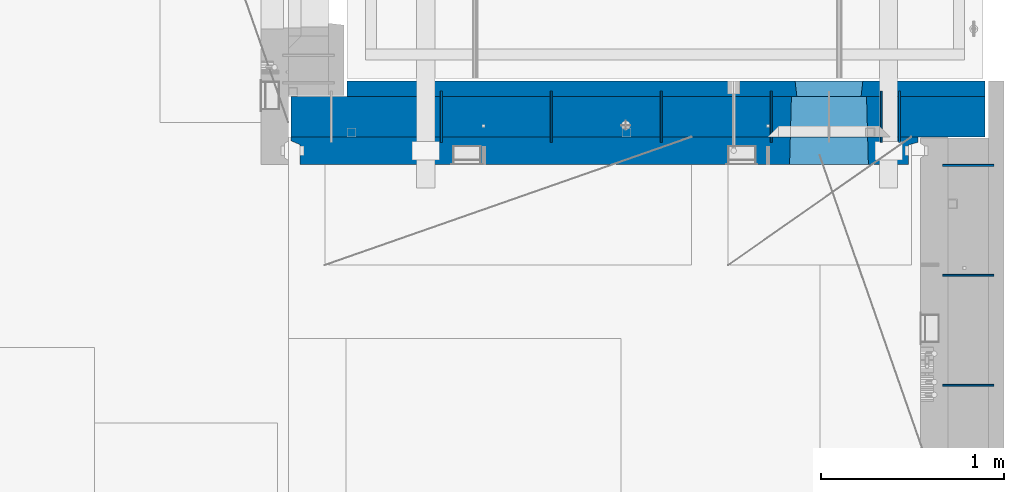
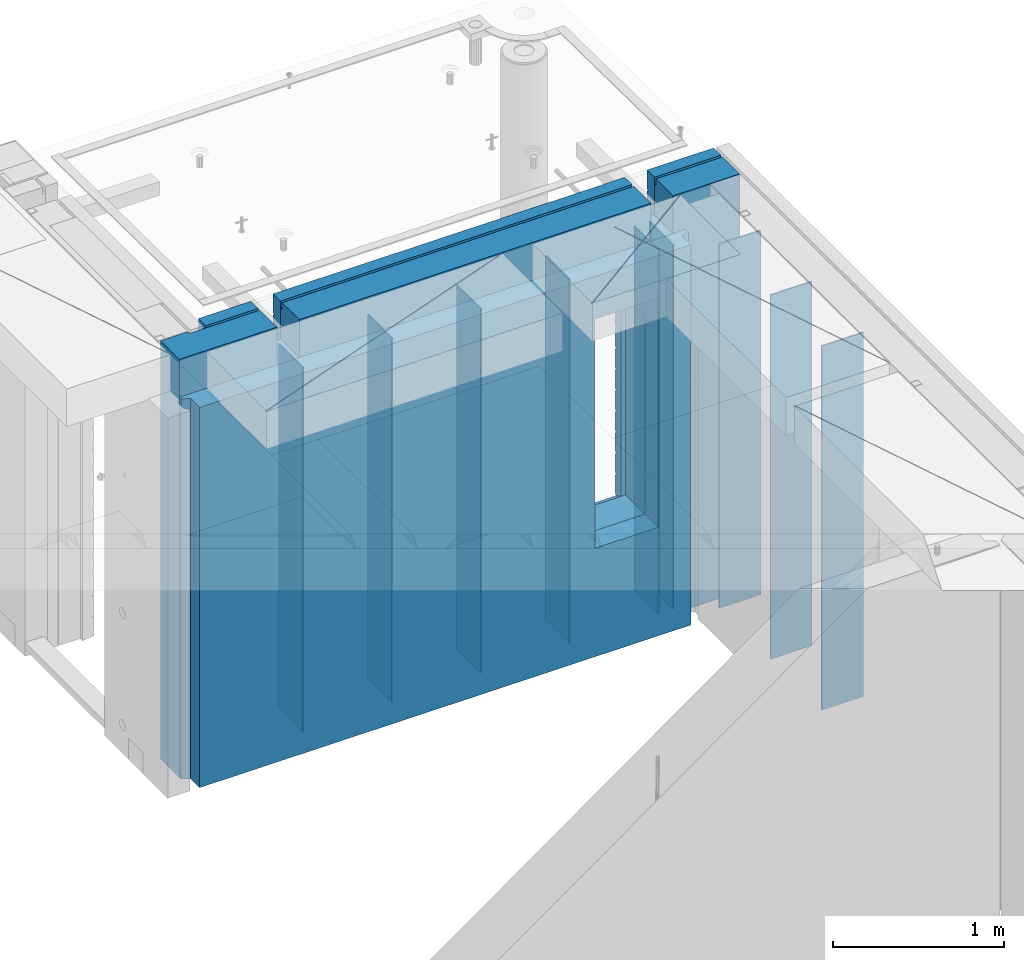
# One storey, part 234 of 341: 12 walls, 2 elements without a shape of their own.
"""IFC2X3 building model written with IfcOpenShell, lengths in millimetres."""

from ifc_helpers import new_model, si_unit, frame, origin_with_axes, place, context, subcontext, project, spatial, faceted_brep, material, type_object, element, aggregate, save


model = new_model("IFC2X3")

# Units and contexts
model_context = context("Model", 3, precision=1e-05, world=origin_with_axes())
body_context = subcontext(model_context, "Body", "Model", "MODEL_VIEW")
ifc_project = project(units=[si_unit("LENGTHUNIT", "METRE", prefix="MILLI"), si_unit("AREAUNIT", "SQUARE_METRE"), si_unit("VOLUMEUNIT", "CUBIC_METRE"), si_unit("MASSUNIT", "GRAM", prefix="KILO"), si_unit("TIMEUNIT", "SECOND"), si_unit("PLANEANGLEUNIT", "RADIAN"), si_unit("SOLIDANGLEUNIT", "STERADIAN"), si_unit("THERMODYNAMICTEMPERATUREUNIT", "DEGREE_CELSIUS"), si_unit("LUMINOUSINTENSITYUNIT", "LUMEN")], contexts=[model_context])

# Site, building, storey
site_placement = place(None, origin_with_axes())
site = spatial("IfcSite", under=ifc_project, at=site_placement, CompositionType="ELEMENT")
building_placement = place(site_placement, origin_with_axes())
building = spatial("IfcBuilding", under=site, at=building_placement, CompositionType="ELEMENT")
storey_placement = place(building_placement, origin_with_axes())
storey = spatial("IfcBuildingStorey", under=building, at=storey_placement, Name="5", CompositionType="ELEMENT", Elevation=0.0)

# Assembly, walls
assembly_1_placement = place(storey_placement, origin_with_axes())
assembly_1 = element("IfcElementAssembly", 1, at=assembly_1_placement, inside=storey, AssemblyPlace="NOTDEFINED", PredefinedType="REINFORCEMENT_UNIT")
ifc_material_1 = material(Name="Undefined")
wall_type_1 = type_object("IfcWallType", PredefinedType="NOTDEFINED")
wall_1_placement = place(assembly_1_placement, frame((32295.0, 20549.9951872276, 95115.0), z_axis=(0.0, 0.0, 1.0), x_axis=(0.0, 1.0, 0.0)))
wall_1 = element("IfcWall", 2, at=wall_1_placement, type_object=wall_type_1, material=ifc_material_1, Name="(PD)", context=body_context, shape_type="Brep", body=[
    faceted_brep([(0.0, 5.0, -1300.0), (0.0, 5.0, 1300.0), (280.0, 5.0, 1300.0), (280.0, 5.0, -1300.0), (0.0, -5.0, 1300.0), (280.0, -5.0, 1300.0), (0.0, -5.0, -1300.0), (280.0, -5.0, -1300.0)], [[[0, 1, 2, 3]], [[1, 4, 5, 2]], [[4, 6, 7, 5]], [[6, 0, 3, 7]], [[5, 7, 3, 2]], [[6, 4, 1, 0]]]),
])
wall_2_placement = place(assembly_1_placement, frame((32895.0, 20549.9951872276, 95115.0), z_axis=(0.0, 0.0, 1.0), x_axis=(0.0, 1.0, 0.0)))
wall_2 = element("IfcWall", 3, at=wall_2_placement, type_object=wall_type_1, material=ifc_material_1, Name="(PD)", context=body_context, shape_type="Brep", body=[
    faceted_brep([(0.0, 5.0, -1300.0), (0.0, 5.0, 1300.0), (280.0, 5.0, 1300.0), (280.0, 5.0, -1300.0), (0.0, -5.0, 1300.0), (280.0, -5.0, 1300.0), (0.0, -5.0, -1300.0), (280.0, -5.0, -1300.0)], [[[0, 1, 2, 3]], [[1, 4, 5, 2]], [[4, 6, 7, 5]], [[6, 0, 3, 7]], [[5, 7, 3, 2]], [[6, 4, 1, 0]]]),
])
wall_3_placement = place(assembly_1_placement, frame((33495.0, 20549.9951872276, 95115.0), z_axis=(0.0, 0.0, 1.0), x_axis=(0.0, 1.0, 0.0)))
wall_3 = element("IfcWall", 4, at=wall_3_placement, type_object=wall_type_1, material=ifc_material_1, Name="(PD)", context=body_context, shape_type="Brep", body=[
    faceted_brep([(0.0, 5.0, -1300.0), (0.0, 5.0, 1300.0), (280.0, 5.0, 1300.0), (280.0, 5.0, -1300.0), (0.0, -5.0, 1300.0), (280.0, -5.0, 1300.0), (0.0, -5.0, -1300.0), (280.0, -5.0, -1300.0)], [[[0, 1, 2, 3]], [[1, 4, 5, 2]], [[4, 6, 7, 5]], [[6, 0, 3, 7]], [[5, 7, 3, 2]], [[6, 4, 1, 0]]]),
])
wall_4_placement = place(assembly_1_placement, frame((34695.0, 20549.9951872276, 95115.0), z_axis=(0.0, 0.0, 1.0), x_axis=(0.0, 1.0, 0.0)))
wall_4 = element("IfcWall", 5, at=wall_4_placement, type_object=wall_type_1, material=ifc_material_1, Name="(PD)", context=body_context, shape_type="Brep", body=[
    faceted_brep([(0.0, 5.0, -1300.0), (0.0, 5.0, 1300.0), (280.0, 5.0, 1300.0), (280.0, 5.0, -1300.0), (0.0, -5.0, 1300.0), (280.0, -5.0, 1300.0), (0.0, -5.0, -1300.0), (280.0, -5.0, -1300.0)], [[[0, 1, 2, 3]], [[1, 4, 5, 2]], [[4, 6, 7, 5]], [[6, 0, 3, 7]], [[5, 7, 3, 2]], [[6, 4, 1, 0]]]),
])
wall_5_placement = place(assembly_1_placement, frame((34795.0, 20549.9951872276, 95115.0), z_axis=(0.0, 0.0, 1.0), x_axis=(0.0, 1.0, 0.0)))
wall_5 = element("IfcWall", 6, at=wall_5_placement, type_object=wall_type_1, material=ifc_material_1, Name="(PD)", context=body_context, shape_type="Brep", body=[
    faceted_brep([(0.0, 5.0, -1300.0), (0.0, 5.0, 1300.0), (280.0, 5.0, 1300.0), (280.0, 5.0, -1300.0), (0.0, -5.0, 1300.0), (280.0, -5.0, 1300.0), (0.0, -5.0, -1300.0), (280.0, -5.0, -1300.0)], [[[0, 1, 2, 3]], [[1, 4, 5, 2]], [[4, 6, 7, 5]], [[6, 0, 3, 7]], [[5, 7, 3, 2]], [[6, 4, 1, 0]]]),
])

assembly_2_placement = place(storey_placement, origin_with_axes())
assembly_2 = element("IfcElementAssembly", 7, at=assembly_2_placement, inside=storey, AssemblyPlace="NOTDEFINED", PredefinedType="REINFORCEMENT_UNIT")
wall_6_placement = place(assembly_2_placement, frame((35030.0, 19225.0002441406, 95115.0), z_axis=(0.0, 0.0, 1.0), x_axis=(1.0, 0.0, 0.0)))
wall_6 = element("IfcWall", 8, at=wall_6_placement, type_object=wall_type_1, material=ifc_material_1, Name="(PD)", context=body_context, shape_type="Brep", body=[
    faceted_brep([(0.0, 5.0, -1300.0), (0.0, 5.0, 1300.0), (280.0, 5.0, 1300.0), (280.0, 5.0, -1300.0), (0.0, -5.0, 1300.0), (280.0, -5.0, 1300.0), (0.0, -5.0, -1300.0), (280.0, -5.0, -1300.0)], [[[0, 1, 2, 3]], [[1, 4, 5, 2]], [[4, 6, 7, 5]], [[6, 0, 3, 7]], [[5, 7, 3, 2]], [[6, 4, 1, 0]]]),
])
wall_7_placement = place(assembly_2_placement, frame((35030.0, 19825.0002441406, 95115.0), z_axis=(0.0, 0.0, 1.0), x_axis=(1.0, 0.0, 0.0)))
wall_7 = element("IfcWall", 9, at=wall_7_placement, type_object=wall_type_1, material=ifc_material_1, Name="(PD)", context=body_context, shape_type="Brep", body=[
    faceted_brep([(0.0, 5.0, -1300.0), (0.0, 5.0, 1300.0), (280.0, 5.0, 1300.0), (280.0, 5.0, -1300.0), (0.0, -5.0, 1300.0), (280.0, -5.0, 1300.0), (0.0, -5.0, -1300.0), (280.0, -5.0, -1300.0)], [[[0, 1, 2, 3]], [[1, 4, 5, 2]], [[4, 6, 7, 5]], [[6, 0, 3, 7]], [[5, 7, 3, 2]], [[6, 4, 1, 0]]]),
])

# Wall
wall_8_placement = place(assembly_1_placement, frame((34095.0, 20549.9951872276, 95115.0), z_axis=(0.0, 0.0, 1.0), x_axis=(0.0, 1.0, 0.0)))
wall_8 = element("IfcWall", 10, at=wall_8_placement, type_object=wall_type_1, material=ifc_material_1, Name="(PD)", context=body_context, shape_type="Brep", body=[
    faceted_brep([(0.0, 5.0, -1300.0), (0.0, 5.0, 1300.0), (280.0, 5.0, 1300.0), (280.0, 5.0, -1300.0), (0.0, -5.0, 1300.0), (280.0, -5.0, 1300.0), (0.0, -5.0, -1300.0), (280.0, -5.0, -1300.0)], [[[0, 1, 2, 3]], [[1, 4, 5, 2]], [[4, 6, 7, 5]], [[6, 0, 3, 7]], [[5, 7, 3, 2]], [[6, 4, 1, 0]]]),
])

wall_9_placement = place(assembly_2_placement, frame((35030.0, 20425.0002441406, 95115.0), z_axis=(0.0, 0.0, 1.0), x_axis=(1.0, 0.0, 0.0)))
wall_9 = element("IfcWall", 11, at=wall_9_placement, type_object=wall_type_1, material=ifc_material_1, Name="(PD)", context=body_context, shape_type="Brep", body=[
    faceted_brep([(0.0, 5.0, -1300.0), (0.0, 5.0, 1300.0), (280.0, 5.0, 1300.0), (280.0, 5.0, -1300.0), (0.0, -5.0, 1300.0), (280.0, -5.0, 1300.0), (0.0, -5.0, -1300.0), (280.0, -5.0, -1300.0)], [[[0, 1, 2, 3]], [[1, 4, 5, 2]], [[4, 6, 7, 5]], [[6, 0, 3, 7]], [[5, 7, 3, 2]], [[6, 4, 1, 0]]]),
])

aggregate(assembly_2, [wall_6, wall_7, wall_9])

ifc_material_2 = material(Name="COS5gt")
wall_type_2 = type_object("IfcWallType", PredefinedType="NOTDEFINED")
wall_10_placement = place(assembly_1_placement, frame((31475.0, 20689.9951872276, 95247.5), z_axis=(0.0, 0.0, 1.0), x_axis=(1.0, 0.0, 0.0)))
wall_10 = element("IfcWall", 12, at=wall_10_placement, type_object=wall_type_2, material=ifc_material_2, context=body_context, shape_type="Brep", body=[
    faceted_brep([(810.0, 110.0, 1442.5), (810.0, 90.0, 1442.5), (3185.0, 90.0, 1442.5), (3185.0, 110.0, 1442.5), (810.0, 90.0, 1492.5), (810.0, -110.0, 1492.5), (3185.0, -110.0, 1492.5), (3185.0, 90.0, 1492.5), (184.0, 90.0, 1442.5), (184.0, 90.0, 1492.5), (660.0, 90.0, 1492.5), (660.0, 90.0, 1442.5), (184.0, 110.0, 1492.5), (184.0, 110.0, 1442.5), (0.0, 110.0, 1492.5), (0.0, -110.0, 1492.5), (660.0, -110.0, 1492.5), (0.0, -110.0, -1492.5), (0.0, 110.0, -1492.5), (3785.0, 90.0, -1492.5), (184.0, 90.0, -1492.5), (184.0, 90.0, -1442.5), (3785.0, 90.0, -1442.5), (3785.0, -110.0, -1492.5), (184.0, 110.0, -1492.5), (184.0, 110.0, -1442.5), (3785.0, 110.0, -1442.5), (3785.0, 110.0, 1442.5), (3785.0, 90.0, 1442.5), (3785.0, 90.0, 1492.5), (3785.0, -110.0, 1492.5), (3335.0, 90.0, 1492.5), (3335.0, -110.0, 1492.5), (3185.0, -110.000000000004, 1222.5), (810.0, -110.0, 1222.5), (660.0, -110.0, 1222.5), (3335.0, -110.000000000004, 1222.5), (2724.05956312561, -110.000000000004, -713.445945945947), (2724.05956312561, -110.000000000007, 913.445945945947), (3145.94145501751, -110.000000000007, 913.445945945947), (3145.94145501751, -110.000000000004, -713.445945945947), (2730.00550907156, 110.0, -702.5), (2730.00550907156, 110.0, 907.5), (2730.00550907156, 110.0, -707.5), (3139.99550907157, 110.0, -707.5), (3109.99550907157, 110.0, -707.5), (2760.00550907156, 110.0, -707.5), (3139.99550907157, 110.0, 907.5), (3139.99550907157, 110.0, -702.5), (660.0, 110.0, 1442.5), (660.0, 109.999999999996, 1222.5), (810.0, 109.999999999996, 1222.5), (3185.0, 109.999999999996, 1222.5), (3335.0, 109.999999999996, 1222.5), (3335.0, 110.0, 1442.5), (3335.0, 90.0, 1442.5)], [[[0, 1, 2, 3]], [[4, 5, 6, 7]], [[8, 9, 10, 11]], [[12, 9, 8, 13]], [[9, 12, 14, 15, 16, 10]], [[17, 15, 14, 18]], [[19, 20, 21, 22]], [[23, 17, 18, 24, 20, 19]], [[25, 21, 20, 24]], [[26, 22, 21, 25]], [[27, 28, 29, 30, 23, 19, 22, 26]], [[30, 29, 31, 32]], [[33, 6, 5, 34, 35, 16, 15, 17, 23, 30, 32, 36], [37, 38, 39, 40]], [[41, 42, 38, 37, 43]], [[40, 44, 45, 46, 43, 37]], [[39, 47, 48, 44, 40]], [[38, 42, 47, 39]], [[27, 26, 25, 24, 18, 14, 12, 13, 49, 50, 51, 0, 3, 52, 53, 54], [41, 43, 46, 45, 44, 48, 47, 42]], [[28, 27, 54, 55]], [[29, 28, 55, 31]], [[54, 53, 36, 32, 31, 55]], [[52, 33, 36, 53]], [[3, 2, 7, 6, 33, 52]], [[1, 4, 7, 2]], [[0, 51, 34, 5, 4, 1]], [[50, 35, 34, 51]], [[49, 11, 10, 16, 35, 50]], [[13, 8, 11, 49]]]),
])

ifc_material_3 = material(Name="CONCRETE/C30/37")
wall_type_3 = type_object("IfcWallType", PredefinedType="NOTDEFINED")
wall_11_placement = place(assembly_1_placement, frame((31780.0, 20842.4951872276, 95247.5), z_axis=(0.0, 0.0, 1.0), x_axis=(1.0, 0.0, 0.0)))
wall_11 = element("IfcWall", 13, at=wall_11_placement, type_object=wall_type_3, material=ifc_material_3, context=body_context, shape_type="Brep", body=[
    faceted_brep([(3480.0, -42.5, 1492.5), (3480.0, 42.5, 1492.5), (3030.0, 42.5, 1492.5), (3030.0, -42.5, 1492.5), (3480.0, 42.4999992431694, 1356.99999988925), (3030.0, 42.4999993410347, 1356.99999988925), (3480.0, 32.4999991127006, 1355.00000040044), (3480.0, 32.4999992507037, 1344.99999999926), (3030.0, 32.4999992507037, 1344.99999999926), (3030.0, 32.4999991127006, 1355.00000040044), (3480.0, 42.4999996036895, 1342.99999994476), (3030.0, 42.4999996549377, 1342.99999994476), (3480.0, 42.4999993831152, 892.999999944761), (0.0, 42.5, 892.999999944761), (0.0, 32.4999992507037, 894.999999999258), (3480.0, 32.4999992507037, 894.999999999258), (0.0, 32.4999991127006, 905.00000040044), (3480.0, 32.4999991127006, 905.00000040044), (3480.0, 42.4999992431694, 906.999999889245), (0.0, 42.5, 906.999999889245), (0.0, 42.5, 1042.99999994476), (3480.0, 42.4999994189675, 1042.99999994476), (0.0, 32.4999992507037, 1044.99999999926), (3480.0, 32.4999992507037, 1044.99999999926), (0.0, 32.4999991127006, 1055.00000040044), (3480.0, 32.4999991127006, 1055.00000040044), (3480.0, 42.4999992431694, 1056.99999988925), (0.0, 42.5, 1056.99999988925), (0.0, 42.5, 1192.99999994476), (3480.0, 42.4999994795144, 1192.99999994476), (0.0, 32.4999992507037, 1194.99999999926), (3480.0, 32.4999992507037, 1194.99999999926), (0.0, 32.4999991127006, 1205.00000040044), (3480.0, 32.4999991127006, 1205.00000040044), (3480.0, 42.4999992431694, 1206.99999988925), (0.0, 42.5, 1206.99999988925), (-3.63797880709171e-12, 32.4999992507037, 1344.99999999926), (-3.63797880709171e-12, 32.4999991127006, 1355.00000040044), (355.0, 32.4999991127006, 1355.00000040044), (355.0, 32.4999992507037, 1344.99999999926), (0.0, 42.5, 1342.99999994476), (355.0, 42.4999999595711, 1342.99999994476), (505.0, 32.4999992507037, 1344.99999999926), (505.0, 32.4999991127006, 1355.00000040044), (2880.0, 32.4999991127006, 1355.00000040044), (2880.0, 32.4999992507037, 1344.99999999926), (505.0, 42.4999999424908, 1342.99999994476), (2880.0, 42.4999996720217, 1342.99999994476), (355.0, 42.4999998715975, 1222.5), (505.0, 42.4999998467429, 1222.5), (2880.0, 42.4999994331811, 1222.5), (3030.0, 42.4999994081736, 1222.5), (355.0, -42.5, 1222.5), (505.0, -42.5, 1222.5), (505.0, 42.5, 1492.5), (505.0, 42.4999998901731, 1356.99999988925), (505.0, -42.5, 1492.5), (2880.0, -42.5, 1492.5), (2880.0, 42.5, 1492.5), (2880.0, 42.4999993736565, 1356.99999988925), (2880.0, -42.5000000000036, 1222.5), (3030.0, -42.5000000000036, 1222.5), (3480.0, -42.5, -1492.5), (3480.0, 42.5, -1492.5), (3480.0, 42.5, -1357.00000005524), (3480.0, 32.4999992507037, -1355.00000000074), (3480.0, 32.4999991127006, -1344.99999959956), (3480.0, 42.4999992431694, -1343.00000011075), (3480.0, 42.4999992794692, -1207.00000005524), (3480.0, 32.4999992507037, -1205.00000000074), (3480.0, 32.4999991127006, -1194.99999959956), (3480.0, 42.4999992431694, -1193.00000011075), (3480.0, 42.4999992814955, -1057.00000005524), (3480.0, 32.4999992507037, -1055.00000000074), (3480.0, 32.4999991127006, -1044.99999959956), (3480.0, 42.4999992431694, -1043.00000011075), (3480.0, 42.4999992837656, -907.000000055239), (3480.0, 32.4999992507037, -905.000000000742), (3480.0, 32.4999991127006, -894.99999959956), (3480.0, 42.4999992431694, -893.000000110755), (3480.0, 42.4999992863159, -757.000000055239), (3480.0, 32.4999992507037, -755.000000000742), (3480.0, 32.4999991127006, -744.99999959956), (3480.0, 42.4999992431694, -743.000000110755), (3480.0, 42.4999992892117, -607.000000055239), (3480.0, 32.4999992507037, -605.000000000742), (3480.0, 32.4999991127006, -594.99999959956), (3480.0, 42.4999992431694, -593.000000110755), (3480.0, 42.4999992925223, -457.000000055239), (3480.0, 32.4999992507037, -455.000000000742), (3480.0, 32.4999991127006, -444.99999959956), (3480.0, 42.4999992431694, -443.000000110755), (3480.0, 42.4999992963494, -307.000000055239), (3480.0, 32.4999992507037, -305.000000000742), (3480.0, 32.4999991127006, -294.99999959956), (3480.0, 42.4999992431694, -293.000000110755), (3480.0, 42.4999993008169, -157.000000055239), (3480.0, 32.4999992507037, -155.000000000742), (3480.0, 32.4999991127006, -144.99999959956), (3480.0, 42.4999992431694, -143.000000110755), (3480.0, 42.4999993061028, -7.00000005523907), (3480.0, 32.4999992507037, -5.00000000074215), (3480.0, 32.4999991127006, 5.0000004004396), (3480.0, 42.4999992431694, 6.99999988924537), (3480.0, 42.4999993124584, 142.999999944761), (3480.0, 32.4999992507037, 144.999999999258), (3480.0, 32.4999991127006, 155.00000040044), (3480.0, 42.4999992431694, 156.999999889245), (3480.0, 42.49999932024, 292.999999944761), (3480.0, 32.4999992507037, 294.999999999258), (3480.0, 32.4999991127006, 305.00000040044), (3480.0, 42.4999992431694, 306.999999889245), (3480.0, 42.4999993299934, 442.999999944761), (3480.0, 32.4999992507037, 444.999999999258), (3480.0, 32.4999991127006, 455.00000040044), (3480.0, 42.4999992431694, 456.999999889245), (3480.0, 42.4999993425699, 592.999999944761), (3480.0, 32.4999992507037, 594.999999999258), (3480.0, 32.4999991127006, 605.00000040044), (3480.0, 42.4999992431694, 606.999999889245), (3480.0, 42.4999993594065, 742.999999944761), (3480.0, 32.4999992507037, 744.999999999258), (3480.0, 32.4999991127006, 755.00000040044), (3480.0, 42.4999992431694, 756.999999889245), (0.0, -42.5, -1492.5), (0.0, 42.5, -1492.5), (0.0, 42.5, -1357.00000005524), (0.0, 32.4999992507037, -1355.00000000074), (0.0, 32.4999991127006, -1344.99999959956), (0.0, 42.5, -1343.00000011075), (0.0, 42.5, -1207.00000005524), (0.0, 32.4999992507037, -1205.00000000074), (0.0, 32.4999991127006, -1194.99999959956), (0.0, 42.5, -1193.00000011075), (0.0, 42.5, -1057.00000005524), (0.0, 32.4999992507037, -1055.00000000074), (0.0, 32.4999991127006, -1044.99999959956), (0.0, 42.5, -1043.00000011075), (0.0, 42.5, -907.000000055239), (0.0, 32.4999992507037, -905.000000000742), (0.0, 32.4999991127006, -894.99999959956), (0.0, 42.5, -893.000000110755), (0.0, 42.5, -757.000000055239), (2445.00550907156, 42.4999994985737, -757.000000055239), (2445.00550907156, 42.5, -757.5), (2814.99550907157, 42.5, -757.5), (2814.99550907157, 42.5, -757.000000055239), (2445.1570241794, 41.2121215834159, -756.742424460826), (2814.84399396603, 41.2121216029336, -756.742424472308), (0.0, 32.4999992507037, -755.000000000742), (0.0, 32.4999991127006, 755.00000040044), (0.0, 42.5, 756.999999889245), (2445.00550907156, 42.4999994682585, 756.999999889245), (2446.18197976419, 32.4999991127006, 755.00000040044), (0.0, 32.4999992507037, 744.999999999258), (2446.18197974795, 32.4999992507037, 744.999999999258), (0.0, 42.5, 742.999999944761), (2445.00550907156, 42.4999995499275, 742.999999944761), (0.0, 42.5, 606.999999889245), (2445.00550907156, 42.4999994682585, 606.999999889245), (3.63797880709171e-12, 32.4999991127006, 605.00000040044), (2446.18197976419, 32.4999991127006, 605.00000040044), (3.63797880709171e-12, 32.4999992507037, 594.999999999258), (2446.18197974795, 32.4999992507037, 594.999999999258), (0.0, 42.5, 592.999999944761), (2445.00550907156, 42.4999995380967, 592.999999944761), (0.0, 42.5, 456.999999889245), (2445.00550907156, 42.4999994682585, 456.999999889245), (0.0, 32.4999991127006, 455.00000040044), (2446.18197976419, 32.4999991127006, 455.00000040044), (0.0, 32.4999992507037, 444.999999999258), (2446.18197974795, 32.4999992507037, 444.999999999258), (0.0, 42.5, 442.999999944761), (2445.00550907156, 42.4999995292637, 442.999999944761), (0.0, 42.5, 306.999999889245), (2445.00550907156, 42.4999994682585, 306.999999889245), (-3.63797880709171e-12, 32.4999991127006, 305.00000040044), (2446.18197976419, 32.4999991127006, 305.00000040044), (-3.63797880709171e-12, 32.4999992507037, 294.999999999258), (2446.18197974795, 32.4999992507037, 294.999999999258), (0.0, 42.5, 292.999999944761), (2445.00550907156, 42.4999995224098, 292.999999944761), (0.0, 42.5, 156.999999889245), (2445.00550907156, 42.4999994682585, 156.999999889245), (-3.63797880709171e-12, 32.4999991127006, 155.00000040044), (2446.18197976419, 32.4999991127006, 155.00000040044), (-3.63797880709171e-12, 32.4999992507037, 144.999999999258), (2446.18197974795, 32.4999992507037, 144.999999999258), (0.0, 42.5, 142.999999944761), (2445.00550907156, 42.4999995169419, 142.999999944761), (0.0, 42.5, 6.99999988924537), (2445.00550907156, 42.4999994682585, 6.99999988924537), (0.0, 32.4999991127006, 5.0000004004396), (2446.18197976419, 32.4999991127006, 5.0000004004396), (0.0, 32.4999992507037, -5.00000000074215), (2446.18197974795, 32.4999992507037, -5.00000000074215), (0.0, 42.5, -7.00000005523907), (2445.00550907156, 42.4999995124781, -7.00000005523907), (0.0, 42.5, -143.000000110755), (2445.00550907156, 42.4999994682585, -143.000000110755), (3.63797880709171e-12, 32.4999991127006, -144.99999959956), (2446.18197976419, 32.4999991127006, -144.99999959956), (3.63797880709171e-12, 32.4999992507037, -155.000000000742), (2446.18197974795, 32.4999992507037, -155.000000000742), (0.0, 42.5, -157.000000055239), (2445.00550907156, 42.4999995087601, -157.000000055239), (0.0, 42.5, -293.000000110755), (2445.00550907156, 42.4999994682585, -293.000000110755), (0.0, 32.4999991127006, -294.99999959956), (2446.18197976419, 32.4999991127006, -294.99999959956), (0.0, 32.4999992507037, -305.000000000742), (2446.18197974795, 32.4999992507037, -305.000000000742), (0.0, 42.5, -307.000000055239), (2445.00550907156, 42.4999995056241, -307.000000055239), (0.0, 42.5, -443.000000110755), (2445.00550907156, 42.4999994682585, -443.000000110755), (0.0, 32.4999991127006, -444.99999959956), (2446.18197976419, 32.4999991127006, -444.99999959956), (0.0, 32.4999992507037, -455.000000000742), (2446.18197974795, 32.4999992507037, -455.000000000742), (0.0, 42.5, -457.000000055239), (2445.00550907156, 42.4999995029357, -457.000000055239), (0.0, 42.5, -593.000000110755), (2445.00550907156, 42.4999994682585, -593.000000110755), (3.63797880709171e-12, 32.4999991127006, -594.99999959956), (2446.18197976419, 32.4999991127006, -594.99999959956), (3.63797880709171e-12, 32.4999992507037, -605.000000000742), (2446.18197974795, 32.4999992507037, -605.000000000742), (0.0, 42.5, -607.000000055239), (2445.00550907156, 42.499999500611, -607.000000055239), (0.0, 42.5, -743.000000110755), (2445.00550907156, 42.4999994682585, -743.000000110755), (0.0, 32.4999991127006, -744.99999959956), (2446.18197976419, 32.4999991127006, -744.99999959956), (2446.18197975344, 32.4999992040284, -751.617646590603), (2455.00550907156, -42.5, -707.5), (2804.99550907157, -42.5, -707.5), (2813.81903838969, 32.4999992040284, -751.617646590603), (2813.81903837895, 32.4999991127006, -744.99999959956), (2814.99550907157, 42.4999993877937, -743.000000110755), (2814.99550907157, 42.4999994250393, -607.000000055239), (2813.81903839519, 32.4999992507037, -605.000000000742), (2813.81903837895, 32.4999991127006, -594.99999959956), (2814.99550907157, 42.4999993877937, -593.000000110755), (2814.99550907157, 42.4999994277168, -457.000000055239), (2813.81903839519, 32.4999992507037, -455.000000000742), (2813.81903837895, 32.4999991127006, -444.99999959956), (2814.99550907157, 42.4999993877937, -443.000000110755), (2814.99550907157, 42.4999994308128, -307.000000055239), (2813.81903839519, 32.4999992507037, -305.000000000742), (2813.81903837895, 32.4999991127006, -294.99999959956), (2814.99550907157, 42.4999993877937, -293.000000110755), (2814.99550907157, 42.4999994344253, -157.000000055239), (2813.81903839519, 32.4999992507037, -155.000000000742), (2813.81903837895, 32.4999991127006, -144.99999959956), (2814.99550907157, 42.4999993877937, -143.000000110755), (2814.99550907157, 42.4999994387035, -7.00000005523907), (2813.81903839519, 32.4999992507037, -5.00000000074215), (2813.81903837895, 32.4999991127006, 5.0000004004396), (2814.99550907157, 42.4999993877937, 6.99999988924537), (2814.99550907157, 42.499999443844, 142.999999944761), (2813.81903839519, 32.4999992507037, 144.999999999258), (2813.81903837895, 32.4999991127006, 155.00000040044), (2814.99550907157, 42.4999993877937, 156.999999889245), (2814.99550907157, 42.4999994501377, 292.999999944761), (2813.81903839519, 32.4999992507037, 294.999999999258), (2813.81903837895, 32.4999991127006, 305.00000040044), (2814.99550907157, 42.4999993877937, 306.999999889245), (2814.99550907157, 42.4999994580285, 442.999999944761), (2813.81903839519, 32.4999992507037, 444.999999999258), (2813.81903837895, 32.4999991127006, 455.00000040044), (2814.99550907157, 42.4999993877937, 456.999999889245), (2814.99550907157, 42.4999994682003, 592.999999944761), (2813.81903839519, 32.4999992507037, 594.999999999258), (2813.81903837895, 32.4999991127006, 605.00000040044), (2814.99550907157, 42.4999993877937, 606.999999889245), (2814.99550907157, 42.4999994818209, 742.999999944761), (2813.81903839519, 32.4999992507037, 744.999999999258), (2813.81903837895, 32.4999991127006, 755.00000040044), (2814.99550907157, 42.4999993877937, 756.999999889245), (2455.00550907156, 42.5, 882.5), (2445.00550907156, 42.5, 882.5), (2814.99550907157, 42.5, 882.5), (2804.99550907157, 42.5, 882.5), (2455.00550907156, -42.5, 882.5), (2455.00550907156, -42.5, 887.5), (2804.99550907157, -42.5, 887.5), (2804.99550907157, -42.5, 882.5), (355.0, -42.5, 1492.5), (0.0, -42.5, 1492.5), (0.0, 42.5, 1492.5), (355.0, 42.5, 1492.5), (0.0, 42.5, 1356.99999988925), (355.0, 42.4999999227948, 1356.99999988925)], [[[0, 1, 2, 3]], [[1, 4, 5, 2]], [[6, 7, 8, 9]], [[7, 10, 11, 8]], [[12, 13, 14, 15]], [[15, 14, 16, 17]], [[18, 17, 16, 19]], [[18, 19, 20, 21]], [[21, 20, 22, 23]], [[23, 22, 24, 25]], [[26, 25, 24, 27]], [[26, 27, 28, 29]], [[29, 28, 30, 31]], [[31, 30, 32, 33]], [[34, 33, 32, 35]], [[36, 37, 38, 39]], [[40, 36, 39, 41]], [[42, 43, 44, 45]], [[46, 42, 45, 47]], [[10, 34, 35, 40, 41, 48, 49, 46, 47, 50, 51, 11]], [[48, 52, 53, 49]], [[54, 55, 43, 42, 46, 49, 53, 56]], [[54, 56, 57, 58]], [[55, 54, 58, 59]], [[43, 55, 59, 44]], [[58, 57, 60, 50, 47, 45, 44, 59]], [[50, 60, 61, 51]], [[2, 5, 9, 8, 11, 51, 61, 3]], [[4, 6, 9, 5]], [[1, 0, 62, 63, 64, 65, 66, 67, 68, 69, 70, 71, 72, 73, 74, 75, 76, 77, 78, 79, 80, 81, 82, 83, 84, 85, 86, 87, 88, 89, 90, 91, 92, 93, 94, 95, 96, 97, 98, 99, 100, 101, 102, 103, 104, 105, 106, 107, 108, 109, 110, 111, 112, 113, 114, 115, 116, 117, 118, 119, 120, 121, 122, 123, 12, 15, 17, 18, 21, 23, 25, 26, 29, 31, 33, 34, 10, 7, 6, 4]], [[124, 125, 63, 62]], [[63, 125, 126, 64]], [[64, 126, 127, 65]], [[65, 127, 128, 66]], [[67, 66, 128, 129]], [[67, 129, 130, 68]], [[68, 130, 131, 69]], [[69, 131, 132, 70]], [[71, 70, 132, 133]], [[71, 133, 134, 72]], [[72, 134, 135, 73]], [[73, 135, 136, 74]], [[75, 74, 136, 137]], [[75, 137, 138, 76]], [[76, 138, 139, 77]], [[77, 139, 140, 78]], [[79, 78, 140, 141]], [[80, 79, 141, 142, 143, 144, 145, 146]], [[143, 147, 144]], [[144, 147, 148, 145]], [[146, 145, 148]], [[147, 143, 142, 149, 81, 80, 146, 148]], [[150, 151, 152, 153]], [[154, 150, 153, 155]], [[156, 154, 155, 157]], [[158, 156, 157, 159]], [[160, 158, 159, 161]], [[162, 160, 161, 163]], [[164, 162, 163, 165]], [[166, 164, 165, 167]], [[168, 166, 167, 169]], [[170, 168, 169, 171]], [[172, 170, 171, 173]], [[174, 172, 173, 175]], [[176, 174, 175, 177]], [[178, 176, 177, 179]], [[180, 178, 179, 181]], [[182, 180, 181, 183]], [[184, 182, 183, 185]], [[186, 184, 185, 187]], [[188, 186, 187, 189]], [[190, 188, 189, 191]], [[192, 190, 191, 193]], [[194, 192, 193, 195]], [[196, 194, 195, 197]], [[198, 196, 197, 199]], [[200, 198, 199, 201]], [[202, 200, 201, 203]], [[204, 202, 203, 205]], [[206, 204, 205, 207]], [[208, 206, 207, 209]], [[210, 208, 209, 211]], [[212, 210, 211, 213]], [[214, 212, 213, 215]], [[216, 214, 215, 217]], [[218, 216, 217, 219]], [[220, 218, 219, 221]], [[222, 220, 221, 223]], [[224, 222, 223, 225]], [[226, 224, 225, 227]], [[228, 226, 227, 229]], [[230, 228, 229, 231]], [[232, 230, 231, 233]], [[234, 235, 236, 237]], [[82, 81, 149, 232, 233, 234, 237, 238]], [[83, 82, 238, 239]], [[84, 83, 239, 240]], [[85, 84, 240, 241]], [[86, 85, 241, 242]], [[87, 86, 242, 243]], [[88, 87, 243, 244]], [[89, 88, 244, 245]], [[90, 89, 245, 246]], [[91, 90, 246, 247]], [[92, 91, 247, 248]], [[93, 92, 248, 249]], [[94, 93, 249, 250]], [[95, 94, 250, 251]], [[96, 95, 251, 252]], [[97, 96, 252, 253]], [[98, 97, 253, 254]], [[99, 98, 254, 255]], [[100, 99, 255, 256]], [[101, 100, 256, 257]], [[102, 101, 257, 258]], [[103, 102, 258, 259]], [[104, 103, 259, 260]], [[105, 104, 260, 261]], [[106, 105, 261, 262]], [[107, 106, 262, 263]], [[108, 107, 263, 264]], [[109, 108, 264, 265]], [[110, 109, 265, 266]], [[111, 110, 266, 267]], [[112, 111, 267, 268]], [[113, 112, 268, 269]], [[114, 113, 269, 270]], [[115, 114, 270, 271]], [[116, 115, 271, 272]], [[117, 116, 272, 273]], [[118, 117, 273, 274]], [[119, 118, 274, 275]], [[120, 119, 275, 276]], [[121, 120, 276, 277]], [[122, 121, 277, 278]], [[123, 122, 278, 279]], [[280, 281, 152, 151, 13, 12, 123, 279, 282, 283]], [[284, 235, 234, 233, 231, 229, 227, 225, 223, 221, 219, 217, 215, 213, 211, 209, 207, 205, 203, 201, 199, 197, 195, 193, 191, 189, 187, 185, 183, 181, 179, 177, 175, 173, 171, 169, 167, 165, 163, 161, 159, 157, 155, 153, 152, 281, 285]], [[280, 283, 282, 286, 285, 281]], [[279, 278, 277, 276, 275, 274, 273, 272, 271, 270, 269, 268, 267, 266, 265, 264, 263, 262, 261, 260, 259, 258, 257, 256, 255, 254, 253, 252, 251, 250, 249, 248, 247, 246, 245, 244, 243, 242, 241, 240, 239, 238, 237, 236, 287, 286, 282]], [[60, 57, 56, 53, 52, 288, 289, 124, 62, 0, 3, 61], [236, 235, 284, 285, 286, 287]], [[290, 289, 288, 291]], [[36, 40, 35, 32, 30, 28, 27, 24, 22, 20, 19, 16, 14, 13, 151, 150, 154, 156, 158, 160, 162, 164, 166, 168, 170, 172, 174, 176, 178, 180, 182, 184, 186, 188, 190, 192, 194, 196, 198, 200, 202, 204, 206, 208, 210, 212, 214, 216, 218, 220, 222, 224, 226, 228, 230, 232, 149, 142, 141, 140, 139, 138, 137, 136, 135, 134, 133, 132, 131, 130, 129, 128, 127, 126, 125, 124, 289, 290, 292, 37]], [[37, 292, 293, 38]], [[291, 288, 52, 48, 41, 39, 38, 293]], [[292, 290, 291, 293]]]),
])

ifc_material_4 = material(Name="CONCRETE/C25/30")
wall_type_4 = type_object("IfcWallType", PredefinedType="NOTDEFINED")
wall_12_placement = place(assembly_1_placement, frame((31475.0, 20504.9951872276, 95112.5), z_axis=(0.0, 0.0, 1.0), x_axis=(1.0, 0.0, 0.0)))
wall_12 = element("IfcWall", 14, at=wall_12_placement, type_object=wall_type_4, material=ifc_material_4, context=body_context, shape_type="Brep", body=[
    faceted_brep([(3370.0, -75.0, 1357.5), (3370.0, -75.0, -1357.5), (3370.0, 32.0, -1357.5), (3370.0, 32.0, 1357.5), (3420.0, 75.0, 1357.5), (0.0, 75.0, 1357.5), (0.0, 53.6645811319431, 1357.5), (49.9951872275633, 32.0, 1357.5), (49.9951872275633, -75.0, 1357.5), (3420.0, 45.0, 1357.5), (49.9951872275633, 32.0, -1357.5), (49.9951872275633, -75.0, -1357.5), (0.0, 53.6645811319431, -1357.5), (0.0, 75.0, -1357.5), (3420.0, 75.0, -1357.5), (3420.0, 45.0, -1357.5), (2720.00550907156, -75.0, 1052.5), (2724.05956312561, 75.0, 1048.44594594595), (3145.94145501751, 75.0, 1048.44594594595), (3149.99550907157, -75.0, 1052.5), (2724.05956312561, 75.0, -578.445945945947), (3145.94145501751, 75.0, -578.445945945947), (3149.99550907157, -75.0, -582.5), (2720.00550907156, -75.0, -582.5)], [[[0, 1, 2, 3]], [[4, 5, 6, 7, 8, 0, 3, 9]], [[7, 10, 11, 8]], [[6, 12, 10, 7]], [[5, 13, 12, 6]], [[1, 11, 10, 12, 13, 14, 15, 2]], [[9, 3, 2, 15]], [[14, 4, 9, 15]], [[16, 17, 18, 19]], [[13, 5, 4, 14], [20, 21, 18, 17]], [[19, 18, 21, 22]], [[8, 11, 1, 0], [23, 16, 19, 22]], [[17, 16, 23, 20]], [[22, 21, 20, 23]]]),
])

aggregate(assembly_1, [wall_1, wall_2, wall_3, wall_4, wall_5, wall_8, wall_11, wall_10, wall_12])

save(model, "model.ifc")
